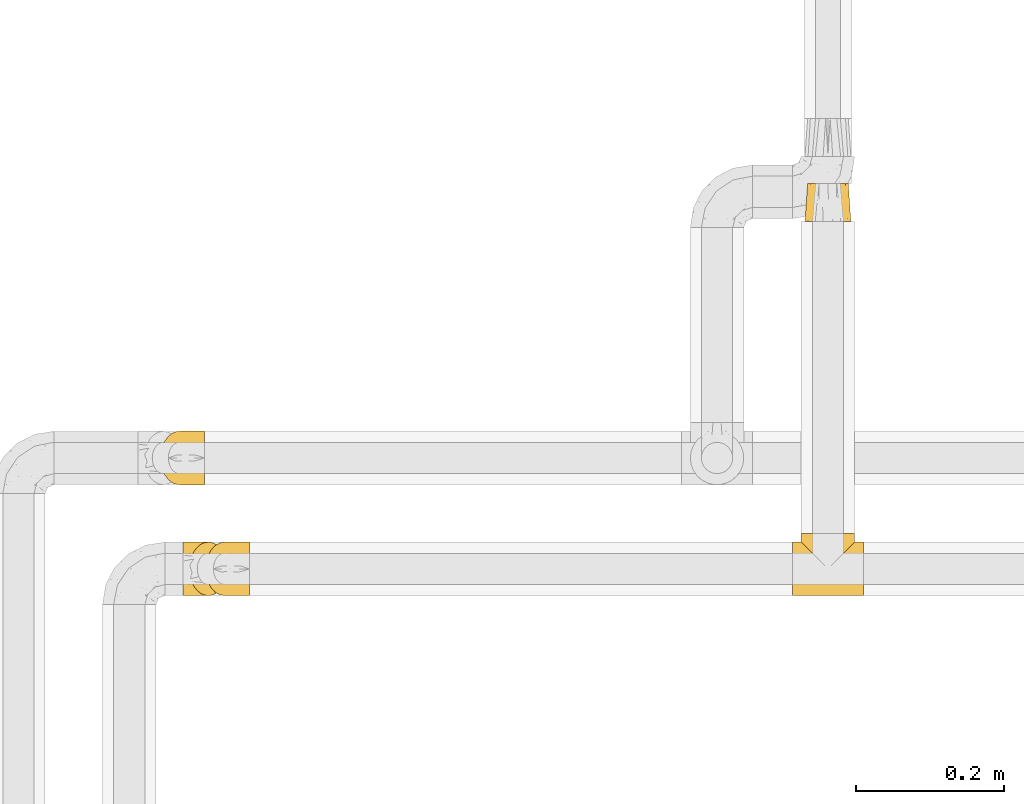
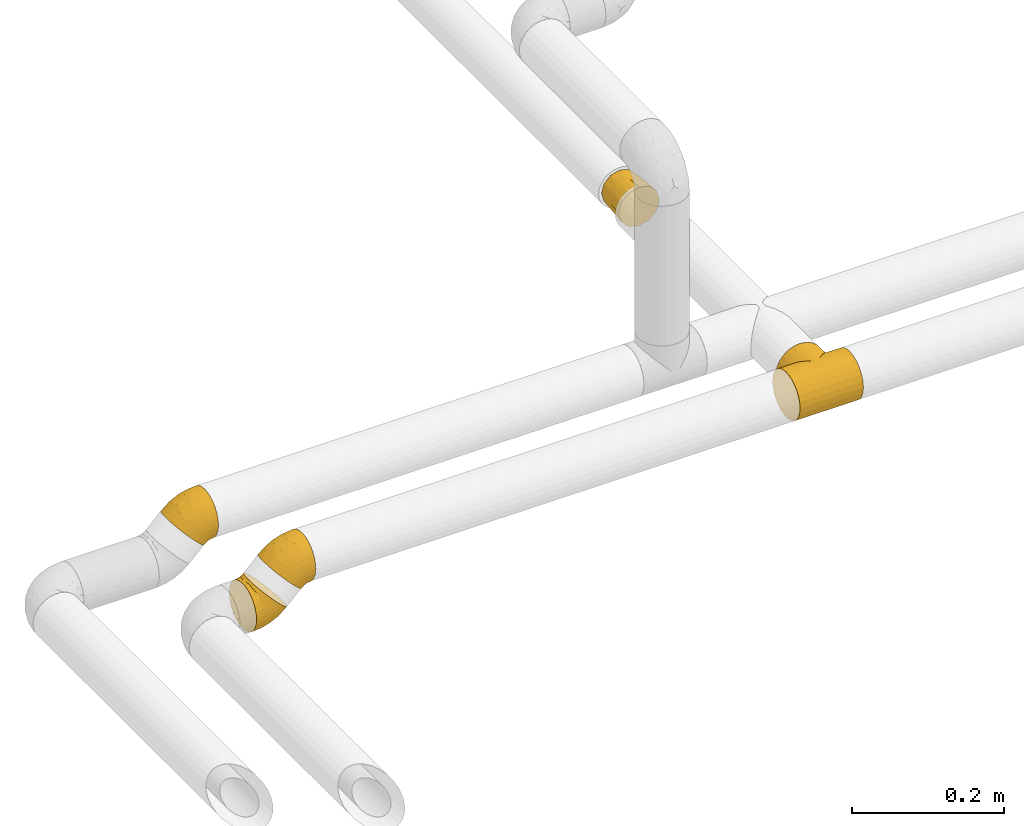
# One storey, part 19 of 39: 5 coverings.
"""IFC2X3 building model written with IfcOpenShell, lengths in millimetres."""

from ifc_helpers import new_model, entity, si_unit, converted_unit, derived_unit, direction, frame, origin, place, context, subcontext, project, spatial, faceted_brep, element, save


model = new_model("IFC2X3")

# Units and contexts
model_context = context("Model", 3, precision=0.01, world=origin(), true_north=direction((6.12303176911189e-17, 1.0)))
body_context = subcontext(model_context, "Body", "Model", "MODEL_VIEW")
ifc_project = project(units=[si_unit("LENGTHUNIT", "METRE", prefix="MILLI"), si_unit("AREAUNIT", "SQUARE_METRE"), si_unit("VOLUMEUNIT", "CUBIC_METRE"), converted_unit("PLANEANGLEUNIT", "DEGREE", entity("IfcRatioMeasure", 0.0174532925199433), si_unit("PLANEANGLEUNIT", "RADIAN"), dimensions=[0, 0, 0, 0, 0, 0, 0]), si_unit("MASSUNIT", "GRAM", prefix="KILO"), derived_unit("MASSDENSITYUNIT", [(si_unit("MASSUNIT", "GRAM", prefix="KILO"), 1), (si_unit("LENGTHUNIT", "METRE"), -3)]), derived_unit("MOMENTOFINERTIAUNIT", [(si_unit("LENGTHUNIT", "METRE"), 4)]), si_unit("TIMEUNIT", "SECOND"), si_unit("FREQUENCYUNIT", "HERTZ"), si_unit("THERMODYNAMICTEMPERATUREUNIT", "DEGREE_CELSIUS"), derived_unit("THERMALTRANSMITTANCEUNIT", [(si_unit("MASSUNIT", "GRAM", prefix="KILO"), 1), (si_unit("THERMODYNAMICTEMPERATUREUNIT", "KELVIN"), -1), (si_unit("TIMEUNIT", "SECOND"), -3)]), derived_unit("VOLUMETRICFLOWRATEUNIT", [(si_unit("LENGTHUNIT", "METRE"), 3), (si_unit("TIMEUNIT", "SECOND"), -1)]), derived_unit("MASSFLOWRATEUNIT", [(si_unit("MASSUNIT", "GRAM", prefix="KILO"), 1), (si_unit("TIMEUNIT", "SECOND"), -1)]), derived_unit("ROTATIONALFREQUENCYUNIT", [(si_unit("TIMEUNIT", "SECOND"), -1)]), si_unit("ELECTRICCURRENTUNIT", "AMPERE"), si_unit("ELECTRICVOLTAGEUNIT", "VOLT"), si_unit("POWERUNIT", "WATT"), si_unit("FORCEUNIT", "NEWTON", prefix="KILO"), si_unit("ILLUMINANCEUNIT", "LUX"), si_unit("LUMINOUSFLUXUNIT", "LUMEN"), si_unit("LUMINOUSINTENSITYUNIT", "CANDELA"), derived_unit("USERDEFINED", [(si_unit("MASSUNIT", "GRAM", prefix="KILO"), -1), (si_unit("LENGTHUNIT", "METRE"), -2), (si_unit("TIMEUNIT", "SECOND"), 3), (si_unit("LUMINOUSFLUXUNIT", "LUMEN"), 1)]), derived_unit("LINEARVELOCITYUNIT", [(si_unit("LENGTHUNIT", "METRE"), 1), (si_unit("TIMEUNIT", "SECOND"), -1)]), si_unit("PRESSUREUNIT", "PASCAL"), derived_unit("USERDEFINED", [(si_unit("LENGTHUNIT", "METRE"), -2), (si_unit("MASSUNIT", "GRAM", prefix="KILO"), 1), (si_unit("TIMEUNIT", "SECOND"), -2)]), derived_unit("LINEARFORCEUNIT", [(si_unit("MASSUNIT", "GRAM", prefix="KILO"), 1), (si_unit("LENGTHUNIT", "METRE"), 1), (si_unit("TIMEUNIT", "SECOND"), -2), (si_unit("LENGTHUNIT", "METRE"), -1)]), derived_unit("PLANARFORCEUNIT", [(si_unit("MASSUNIT", "GRAM", prefix="KILO"), 1), (si_unit("LENGTHUNIT", "METRE"), 1), (si_unit("TIMEUNIT", "SECOND"), -2), (si_unit("LENGTHUNIT", "METRE"), -2)])], contexts=[model_context])

# Site, building, storey
site_placement = place(None, origin())
site = spatial("IfcSite", under=ifc_project, at=site_placement, CompositionType="ELEMENT")
building_placement = place(site_placement, origin())
building = spatial("IfcBuilding", under=site, at=building_placement, CompositionType="ELEMENT")
storey_placement = place(building_placement, frame((0.0, 0.0, 24000.0)))
storey = spatial("IfcBuildingStorey", under=building, at=storey_placement, Name="07", CompositionType="ELEMENT", Elevation=24000.0)

# Coverings
covering_1_placement = place(storey_placement, frame((68741.41, 2687.56, 2992.16)))
element("IfcCovering", 1, at=covering_1_placement, inside=storey, Name=":ADSK_", ObjectType=":ADSK_", PredefinedType="INSULATION", context=body_context, shape_type="Brep", body=[
    faceted_brep([(10.58, 29.74, 76.81), (12.48, 22.08, 74.91), (15.53, 15.22, 71.86), (19.58, 9.49, 67.81), (24.43, 5.18, 62.96), (29.84, 2.5, 57.55), (35.54, 1.6, 51.85), (41.24, 2.5, 46.16), (46.65, 5.18, 40.74), (51.5, 9.5, 35.89), (55.55, 15.23, 31.84), (58.6, 22.09, 28.79), (60.49, 29.74, 26.9), (61.13, 37.8, 26.26), (60.49, 45.85, 26.9), (58.6, 53.51, 28.79), (55.55, 60.37, 31.84), (51.49, 66.1, 35.9), (46.64, 70.41, 40.75), (41.23, 73.09, 46.16), (35.54, 74.0, 51.85), (29.84, 73.09, 57.55), (24.43, 70.41, 62.96), (19.57, 66.09, 67.82), (15.52, 60.36, 71.87), (12.47, 53.5, 74.92), (10.58, 45.85, 76.81), (9.94, 37.8, 77.45), (1.6, 47.16, 72.76), (1.6, 55.9, 69.15), (1.6, 63.39, 63.39), (1.6, 69.15, 55.9), (1.6, 72.76, 47.16), (1.6, 74.0, 37.8), (1.6, 72.76, 28.43), (1.6, 69.15, 19.7), (1.6, 63.39, 12.2), (1.6, 55.9, 6.45), (1.6, 47.16, 2.83), (1.6, 37.8, 1.6), (1.6, 28.43, 2.83), (1.6, 19.7, 6.45), (1.6, 12.2, 12.2), (1.6, 6.45, 19.7), (1.6, 2.83, 28.43), (1.6, 1.6, 37.8), (1.6, 2.83, 47.16), (1.6, 6.45, 55.9), (1.6, 12.2, 63.39), (1.6, 19.7, 69.15), (1.6, 28.43, 72.76), (1.6, 37.8, 74.0), (40.9, 12.92, 22.74), (23.39, 37.8, 4.46), (14.99, 29.25, 3.7), (16.52, 16.37, 10.07), (43.7, 37.8, 12.88), (27.85, 28.37, 7.11), (16.2, 10.58, 15.43), (45.46, 26.39, 16.1), (32.41, 19.73, 12.65), (28.47, 8.23, 22.37), (28.27, 13.79, 15.59), (16.35, 4.79, 24.68), (16.28, 2.34, 32.48), (31.57, 4.14, 32.28), (16.21, 23.1, 6.04), (19.96, 1.6, 41.45), (29.27, 2.14, 39.15), (46.54, 19.09, 20.84), (40.55, 7.62, 30.06), (30.91, 1.6, 48.76), (26.28, 1.6, 45.67), (12.51, 1.6, 39.97), (7.05, 1.6, 38.88), (7.17, 30.94, 74.66), (7.72, 24.2, 72.71), (16.09, 3.85, 53.48), (16.64, 2.21, 47.28), (21.27, 2.29, 49.91), (12.03, 8.54, 61.24), (11.95, 3.41, 50.6), (6.97, 7.2, 57.65), (6.75, 11.87, 63.65), (6.73, 3.16, 48.68), (25.51, 2.54, 53.98), (5.81, 19.63, 69.65), (9.9, 16.09, 68.68), (19.14, 4.98, 58.19), (15.24, 10.44, 65.7), (6.11, 37.8, 74.89), (5.8, 55.94, 69.66), (6.75, 63.73, 63.65), (12.51, 74.0, 39.97), (11.94, 72.18, 50.61), (16.64, 73.38, 47.29), (7.72, 51.38, 72.71), (30.91, 74.0, 48.76), (9.89, 59.48, 68.68), (6.73, 72.43, 48.68), (7.05, 74.0, 38.88), (6.97, 68.39, 57.65), (19.13, 70.6, 58.2), (16.08, 71.73, 53.49), (12.02, 67.04, 61.25), (25.5, 73.05, 53.98), (21.26, 73.3, 49.91), (5.43, 44.89, 73.9), (26.28, 74.0, 45.67), (15.24, 65.14, 65.71), (19.96, 74.0, 41.45), (16.26, 73.25, 32.48), (31.56, 71.45, 32.29), (16.36, 70.8, 24.69), (40.9, 62.68, 22.75), (46.54, 56.51, 20.84), (32.4, 55.87, 12.65), (45.46, 49.21, 16.1), (14.99, 46.35, 3.71), (29.27, 73.45, 39.15), (27.84, 47.23, 7.11), (16.21, 65.01, 15.43), (16.52, 59.22, 10.07), (16.2, 52.49, 6.04), (28.47, 67.37, 22.38), (40.54, 67.98, 30.07), (28.28, 61.79, 15.59)], [[[0, 1, 2, 3, 4, 5, 6, 7, 8, 9, 10, 11, 12, 13, 14, 15, 16, 17, 18, 19, 20, 21, 22, 23, 24, 25, 26, 27]], [[28, 29, 30, 31, 32, 33, 34, 35, 36, 37, 38, 39, 40, 41, 42, 43, 44, 45, 46, 47, 48, 49, 50, 51]], [[9, 52, 10]], [[39, 53, 54]], [[41, 55, 42]], [[53, 56, 57]], [[58, 43, 42]], [[59, 60, 57]], [[61, 58, 62]], [[58, 63, 43]], [[64, 45, 44]], [[63, 61, 65]], [[54, 66, 40]], [[67, 64, 68]], [[55, 58, 42]], [[69, 52, 60]], [[59, 57, 56]], [[56, 12, 59]], [[11, 10, 69]], [[11, 69, 59]], [[65, 64, 63]], [[13, 12, 56]], [[70, 52, 9]], [[43, 63, 44]], [[60, 55, 66]], [[68, 6, 71, 72, 67]], [[8, 7, 65]], [[65, 61, 70]], [[59, 69, 60]], [[52, 69, 10]], [[8, 70, 9]], [[54, 57, 66]], [[7, 68, 65]], [[11, 59, 12]], [[64, 67, 73, 74, 45]], [[63, 64, 44]], [[66, 55, 41]], [[60, 52, 62]], [[65, 68, 64]], [[6, 68, 7]], [[62, 58, 55]], [[58, 61, 63]], [[60, 62, 55]], [[61, 62, 52]], [[40, 66, 41]], [[60, 66, 57]], [[65, 70, 8]], [[52, 70, 61]], [[39, 54, 40]], [[53, 57, 54]], [[75, 76, 0]], [[77, 78, 79]], [[80, 81, 77]], [[82, 83, 48]], [[84, 73, 81]], [[1, 0, 76]], [[85, 5, 4]], [[76, 75, 50]], [[86, 50, 49]], [[51, 50, 75]], [[86, 87, 76]], [[47, 84, 82]], [[78, 73, 67]], [[4, 88, 85]], [[89, 88, 3]], [[4, 3, 88]], [[85, 72, 71]], [[6, 5, 71]], [[46, 84, 47]], [[47, 82, 48]], [[73, 84, 74]], [[90, 75, 27]], [[72, 85, 79]], [[89, 87, 80]], [[1, 87, 2]], [[85, 71, 5]], [[1, 76, 87]], [[83, 49, 48]], [[77, 79, 88]], [[2, 89, 3]], [[67, 72, 79]], [[79, 85, 88]], [[87, 89, 2]], [[88, 89, 80]], [[81, 80, 82]], [[83, 82, 80]], [[80, 77, 88]], [[78, 77, 81]], [[80, 87, 83]], [[83, 87, 86]], [[73, 78, 81]], [[79, 78, 67]], [[46, 74, 84]], [[82, 84, 81]], [[46, 45, 74]], [[27, 75, 0]], [[75, 90, 51]], [[50, 86, 76]], [[83, 86, 49]], [[29, 91, 92]], [[93, 94, 95]], [[26, 25, 96]], [[21, 20, 97]], [[91, 28, 96]], [[25, 24, 98]], [[99, 100, 32]], [[101, 31, 30]], [[102, 103, 104]], [[94, 99, 101]], [[102, 105, 106]], [[91, 96, 98]], [[51, 90, 107]], [[103, 95, 94]], [[90, 27, 26]], [[92, 91, 98]], [[96, 25, 98]], [[97, 108, 105]], [[99, 32, 31]], [[98, 24, 109]], [[109, 24, 23]], [[102, 23, 22]], [[92, 104, 101]], [[21, 105, 22]], [[106, 103, 102]], [[105, 21, 97]], [[107, 96, 28]], [[109, 102, 104]], [[102, 22, 105]], [[96, 107, 26]], [[108, 110, 106]], [[106, 105, 108]], [[102, 109, 23]], [[98, 109, 104]], [[92, 101, 30]], [[104, 94, 101]], [[95, 106, 110]], [[104, 103, 94]], [[29, 92, 30]], [[98, 104, 92]], [[106, 95, 103]], [[93, 95, 110]], [[101, 99, 31]], [[93, 99, 94]], [[100, 99, 93]], [[100, 33, 32]], [[28, 91, 29]], [[51, 107, 28]], [[26, 107, 90]], [[111, 112, 113]], [[114, 115, 116]], [[111, 33, 100, 93, 110]], [[114, 17, 16]], [[117, 115, 15]], [[35, 34, 113]], [[38, 118, 39]], [[111, 110, 119]], [[117, 120, 116]], [[111, 113, 34]], [[121, 35, 113]], [[37, 122, 123]], [[33, 111, 34]], [[36, 122, 37]], [[18, 112, 19]], [[113, 124, 121]], [[112, 18, 125]], [[38, 123, 118]], [[125, 18, 17]], [[113, 112, 124]], [[112, 111, 119]], [[124, 125, 114]], [[120, 117, 56]], [[115, 16, 15]], [[14, 13, 56]], [[120, 56, 53]], [[14, 56, 117]], [[115, 117, 116]], [[115, 114, 16]], [[14, 117, 15]], [[126, 116, 122]], [[119, 20, 19]], [[123, 38, 37]], [[122, 121, 126]], [[121, 122, 36]], [[123, 116, 120]], [[119, 110, 108, 97, 20]], [[112, 119, 19]], [[35, 121, 36]], [[126, 124, 114]], [[124, 126, 121]], [[116, 126, 114]], [[116, 123, 122]], [[123, 120, 118]], [[114, 125, 17]], [[112, 125, 124]], [[120, 53, 118]], [[39, 118, 53]]]),
])
covering_2_placement = place(storey_placement, frame((68771.64, 2687.56, 3038.7)))
element("IfcCovering", 2, at=covering_2_placement, inside=storey, Name=":ADSK_", ObjectType=":ADSK_", PredefinedType="INSULATION", context=body_context, shape_type="Brep", body=[
    faceted_brep([(61.13, 45.85, 5.96), (61.13, 53.51, 8.64), (61.13, 60.37, 12.95), (61.13, 66.1, 18.69), (61.13, 70.41, 25.55), (61.13, 73.09, 33.2), (61.13, 74.0, 41.25), (61.13, 73.09, 49.31), (61.13, 70.41, 56.96), (61.13, 66.09, 63.83), (61.13, 60.36, 69.56), (61.13, 53.5, 73.87), (61.13, 45.85, 76.54), (61.13, 37.8, 77.45), (61.13, 29.74, 76.54), (61.13, 22.08, 73.86), (61.13, 15.22, 69.55), (61.13, 9.49, 63.82), (61.13, 5.18, 56.95), (61.13, 2.5, 49.3), (61.13, 1.6, 41.25), (61.13, 2.5, 33.19), (61.13, 5.18, 25.54), (61.13, 9.5, 18.68), (61.13, 15.23, 12.94), (61.13, 22.09, 8.63), (61.13, 29.74, 5.96), (61.13, 37.8, 5.05), (51.92, 28.43, 2.47), (49.36, 19.7, 5.02), (45.29, 12.2, 9.09), (39.99, 6.45, 14.39), (33.82, 2.83, 20.57), (27.19, 1.6, 27.19), (20.57, 2.83, 33.82), (14.39, 6.45, 39.99), (9.09, 12.2, 45.29), (5.02, 19.7, 49.36), (2.47, 28.43, 51.92), (1.6, 37.8, 52.79), (2.47, 47.16, 51.92), (5.02, 55.9, 49.36), (9.09, 63.39, 45.29), (14.39, 69.15, 39.99), (20.57, 72.76, 33.82), (27.19, 74.0, 27.19), (33.82, 72.76, 20.57), (39.99, 69.15, 14.39), (45.29, 63.39, 9.09), (49.36, 55.9, 5.02), (51.92, 47.16, 2.47), (52.79, 37.8, 1.6), (44.34, 62.67, 65.63), (19.03, 37.8, 66.17), (12.56, 46.34, 60.77), (18.15, 59.22, 57.35), (39.34, 37.8, 74.58), (24.06, 47.22, 67.46), (21.7, 65.01, 53.34), (42.87, 49.2, 73.56), (31.19, 55.86, 66.76), (35.29, 67.36, 57.1), (30.36, 61.8, 61.76), (28.36, 70.8, 46.9), (33.81, 73.25, 41.33), (44.49, 71.45, 52.29), (15.07, 52.49, 59.98), (42.76, 74.0, 37.6), (47.72, 73.45, 45.8), (46.98, 56.5, 70.97), (49.26, 67.97, 60.21), (55.68, 74.0, 40.17), (50.22, 74.0, 39.08), (36.45, 74.0, 33.38), (31.82, 74.0, 30.28), (57.2, 44.65, 5.07), (56.21, 51.39, 6.84), (48.53, 71.74, 26.36), (44.54, 73.38, 31.12), (49.68, 73.3, 32.54), (51.15, 67.05, 17.99), (43.56, 72.18, 25.46), (45.04, 68.39, 16.95), (49.12, 63.72, 12.56), (38.52, 72.43, 23.12), (55.54, 73.05, 32.66), (52.69, 55.96, 7.64), (54.9, 59.5, 11.23), (54.02, 70.61, 25.18), (56.57, 65.15, 17.11), (56.62, 37.8, 4.15), (52.7, 19.65, 7.64), (49.12, 11.87, 12.56), (36.45, 1.6, 33.38), (43.57, 3.41, 25.45), (44.54, 2.21, 31.11), (56.21, 24.21, 6.83), (55.68, 1.6, 40.17), (54.9, 16.11, 11.22), (38.52, 3.16, 23.12), (31.82, 1.6, 30.28), (45.03, 7.2, 16.95), (54.03, 4.99, 25.16), (48.53, 3.86, 26.34), (51.15, 8.55, 17.98), (55.54, 2.54, 32.65), (49.66, 2.29, 32.53), (55.43, 30.7, 4.38), (50.22, 1.6, 39.08), (56.58, 10.45, 17.1), (42.76, 1.6, 37.6), (33.81, 2.34, 41.32), (44.49, 4.14, 52.28), (28.37, 4.79, 46.9), (44.35, 12.91, 65.62), (46.98, 19.08, 70.96), (31.2, 19.72, 66.75), (42.87, 26.38, 73.55), (12.56, 29.24, 60.77), (47.71, 2.14, 45.8), (24.05, 28.36, 67.45), (21.71, 10.58, 53.34), (18.14, 16.37, 57.35), (15.06, 23.1, 59.97), (35.3, 8.22, 57.09), (49.26, 7.61, 60.2), (30.36, 13.8, 61.76)], [[[0, 1, 2, 3, 4, 5, 6, 7, 8, 9, 10, 11, 12, 13, 14, 15, 16, 17, 18, 19, 20, 21, 22, 23, 24, 25, 26, 27]], [[28, 29, 30, 31, 32, 33, 34, 35, 36, 37, 38, 39, 40, 41, 42, 43, 44, 45, 46, 47, 48, 49, 50, 51]], [[9, 52, 10]], [[39, 53, 54]], [[41, 55, 42]], [[53, 56, 57]], [[58, 43, 42]], [[59, 60, 57]], [[61, 58, 62]], [[58, 63, 43]], [[64, 45, 44]], [[63, 61, 65]], [[54, 66, 40]], [[67, 64, 68]], [[55, 58, 42]], [[69, 52, 60]], [[59, 57, 56]], [[56, 12, 59]], [[11, 10, 69]], [[11, 69, 59]], [[65, 64, 63]], [[13, 12, 56]], [[70, 52, 9]], [[43, 63, 44]], [[60, 55, 66]], [[68, 6, 71, 72, 67]], [[8, 7, 65]], [[65, 61, 70]], [[59, 69, 60]], [[52, 69, 10]], [[8, 70, 9]], [[54, 57, 66]], [[7, 68, 65]], [[11, 59, 12]], [[64, 67, 73, 74, 45]], [[63, 64, 44]], [[66, 55, 41]], [[60, 52, 62]], [[65, 68, 64]], [[6, 68, 7]], [[62, 58, 55]], [[58, 61, 63]], [[60, 62, 55]], [[61, 62, 52]], [[40, 66, 41]], [[60, 66, 57]], [[65, 70, 8]], [[52, 70, 61]], [[39, 54, 40]], [[53, 57, 54]], [[75, 76, 0]], [[77, 78, 79]], [[80, 81, 77]], [[82, 83, 48]], [[84, 73, 81]], [[1, 0, 76]], [[85, 5, 4]], [[76, 75, 50]], [[86, 50, 49]], [[51, 50, 75]], [[86, 87, 76]], [[47, 84, 82]], [[78, 73, 67]], [[4, 88, 85]], [[89, 88, 3]], [[4, 3, 88]], [[85, 72, 71]], [[6, 5, 71]], [[46, 84, 47]], [[47, 82, 48]], [[73, 84, 74]], [[90, 75, 27]], [[72, 85, 79]], [[89, 87, 80]], [[1, 87, 2]], [[85, 71, 5]], [[1, 76, 87]], [[83, 49, 48]], [[77, 79, 88]], [[2, 89, 3]], [[67, 72, 79]], [[79, 85, 88]], [[87, 89, 2]], [[88, 89, 80]], [[81, 80, 82]], [[83, 82, 80]], [[80, 77, 88]], [[78, 77, 81]], [[80, 87, 83]], [[83, 87, 86]], [[73, 78, 81]], [[79, 78, 67]], [[46, 74, 84]], [[82, 84, 81]], [[46, 45, 74]], [[27, 75, 0]], [[75, 90, 51]], [[50, 86, 76]], [[83, 86, 49]], [[29, 91, 92]], [[93, 94, 95]], [[26, 25, 96]], [[21, 20, 97]], [[91, 28, 96]], [[25, 24, 98]], [[99, 100, 32]], [[101, 31, 30]], [[102, 103, 104]], [[94, 99, 101]], [[102, 105, 106]], [[91, 96, 98]], [[51, 90, 107]], [[103, 95, 94]], [[90, 27, 26]], [[92, 91, 98]], [[96, 25, 98]], [[97, 108, 105]], [[99, 32, 31]], [[98, 24, 109]], [[109, 24, 23]], [[102, 23, 22]], [[92, 104, 101]], [[21, 105, 22]], [[106, 103, 102]], [[105, 21, 97]], [[107, 96, 28]], [[109, 102, 104]], [[102, 22, 105]], [[96, 107, 26]], [[108, 110, 106]], [[106, 105, 108]], [[102, 109, 23]], [[98, 109, 104]], [[92, 101, 30]], [[104, 94, 101]], [[95, 106, 110]], [[104, 103, 94]], [[29, 92, 30]], [[98, 104, 92]], [[106, 95, 103]], [[93, 95, 110]], [[101, 99, 31]], [[93, 99, 94]], [[100, 99, 93]], [[100, 33, 32]], [[28, 91, 29]], [[51, 107, 28]], [[26, 107, 90]], [[111, 112, 113]], [[114, 115, 116]], [[111, 33, 100, 93, 110]], [[114, 17, 16]], [[117, 115, 15]], [[35, 34, 113]], [[38, 118, 39]], [[111, 110, 119]], [[117, 120, 116]], [[111, 113, 34]], [[121, 35, 113]], [[37, 122, 123]], [[33, 111, 34]], [[36, 122, 37]], [[18, 112, 19]], [[113, 124, 121]], [[112, 18, 125]], [[38, 123, 118]], [[125, 18, 17]], [[113, 112, 124]], [[112, 111, 119]], [[124, 125, 114]], [[120, 117, 56]], [[115, 16, 15]], [[14, 13, 56]], [[120, 56, 53]], [[14, 56, 117]], [[115, 117, 116]], [[115, 114, 16]], [[14, 117, 15]], [[126, 116, 122]], [[119, 20, 19]], [[123, 38, 37]], [[122, 121, 126]], [[121, 122, 36]], [[123, 116, 120]], [[119, 110, 108, 97, 20]], [[112, 119, 19]], [[35, 121, 36]], [[126, 124, 114]], [[124, 126, 121]], [[116, 126, 114]], [[116, 123, 122]], [[123, 120, 118]], [[114, 125, 17]], [[112, 125, 124]], [[120, 53, 118]], [[39, 118, 53]]]),
])
covering_3_placement = place(storey_placement, frame((69567.01, 2687.56, 3042.17)))
element("IfcCovering", 3, at=covering_3_placement, inside=storey, Name=":ADSK_", ObjectType=":ADSK_", PredefinedType="INSULATION", context=body_context, shape_type="Brep", body=[
    faceted_brep([(41.92, 43.88, 2.11), (0.0, 37.8, 1.6), (0.0, 47.16, 2.83), (0.0, 55.9, 6.45), (35.92, 49.87, 3.67), (24.64, 61.15, 10.14), (0.0, 63.39, 12.2), (30.12, 55.68, 6.32), (48.0, 37.8, 1.6), (54.08, 43.88, 2.11), (96.0, 37.8, 1.6), (19.71, 66.09, 15.21), (0.0, 69.15, 19.7), (15.62, 70.18, 21.61), (0.0, 72.76, 28.43), (12.82, 72.98, 29.28), (0.0, 74.0, 37.8), (11.8, 74.0, 37.8), (12.81, 72.98, 46.3), (0.0, 72.76, 47.16), (15.61, 70.18, 53.97), (0.0, 69.15, 55.9), (19.7, 66.09, 60.37), (0.0, 63.39, 63.39), (24.64, 61.16, 65.45), (30.11, 55.69, 69.27), (0.0, 55.9, 69.15), (35.92, 49.88, 71.92), (0.0, 47.16, 72.76), (41.91, 43.88, 73.48), (0.0, 37.8, 74.0), (48.0, 37.8, 74.0), (54.09, 43.88, 73.48), (96.0, 37.8, 74.0), (96.0, 19.7, 69.15), (96.0, 12.2, 63.39), (96.0, 6.45, 55.9), (96.0, 2.83, 47.17), (96.0, 1.6, 37.8), (96.0, 2.83, 28.43), (96.0, 6.45, 19.7), (96.0, 12.2, 12.2), (96.0, 19.7, 6.45), (96.0, 28.43, 2.83), (96.0, 47.16, 2.83), (96.0, 55.9, 6.45), (96.0, 63.39, 12.2), (96.0, 69.15, 19.7), (96.0, 72.76, 28.43), (96.0, 74.0, 37.8), (96.0, 72.76, 47.17), (96.0, 69.15, 55.9), (96.0, 63.39, 63.39), (96.0, 55.9, 69.15), (96.0, 47.16, 72.76), (96.0, 28.43, 72.76), (0.0, 12.2, 12.2), (0.0, 6.45, 19.7), (0.0, 2.83, 28.43), (0.0, 1.6, 37.8), (0.0, 2.83, 47.16), (0.0, 6.45, 55.9), (0.0, 12.2, 63.39), (0.0, 19.7, 69.15), (0.0, 28.43, 72.76), (0.0, 28.43, 2.83), (0.0, 19.7, 6.45), (60.08, 49.87, 3.67), (65.88, 55.68, 6.32), (71.36, 61.15, 10.14), (76.29, 66.09, 15.21), (80.38, 70.18, 21.61), (83.18, 72.98, 29.28), (84.2, 74.0, 37.8), (83.19, 72.98, 46.3), (80.39, 70.18, 53.97), (76.3, 66.09, 60.37), (71.36, 61.16, 65.45), (65.89, 55.69, 69.27), (60.08, 49.88, 71.92), (13.03, 85.8, 28.43), (11.8, 85.8, 37.8), (13.03, 85.8, 47.16), (16.65, 85.8, 55.9), (22.4, 85.8, 63.39), (29.9, 85.8, 69.15), (38.63, 85.8, 72.76), (48.0, 85.8, 74.0), (57.37, 85.8, 72.76), (66.1, 85.8, 69.15), (73.6, 85.8, 63.39), (79.35, 85.8, 55.9), (82.97, 85.8, 47.17), (84.2, 85.8, 37.8), (82.97, 85.8, 28.43), (79.35, 85.8, 19.7), (73.6, 85.8, 12.2), (66.1, 85.8, 6.45), (57.37, 85.8, 2.83), (48.0, 85.8, 1.6), (38.63, 85.8, 2.83), (29.9, 85.8, 6.45), (22.4, 85.8, 12.2), (16.65, 85.8, 19.7)], [[[0, 1, 2]], [[2, 3, 4]], [[5, 3, 6]], [[5, 7, 3]], [[0, 8, 1]], [[8, 9, 10]], [[7, 4, 3]], [[0, 2, 4]], [[11, 6, 12]], [[13, 12, 14]], [[15, 14, 16]], [[13, 11, 12]], [[17, 15, 16]], [[13, 14, 15]], [[6, 11, 5]], [[18, 16, 19]], [[20, 19, 21]], [[22, 21, 23]], [[18, 17, 16]], [[22, 20, 21]], [[18, 19, 20]], [[23, 24, 22]], [[25, 24, 26]], [[26, 24, 23]], [[27, 26, 28]], [[29, 28, 30]], [[27, 25, 26]], [[31, 29, 30]], [[32, 31, 33]], [[27, 28, 29]], [[34, 35, 36, 37, 38, 39, 40, 41, 42, 43, 10, 44, 45, 46, 47, 48, 49, 50, 51, 52, 53, 54, 33, 55]], [[56, 57, 58, 59, 60, 61, 62, 63, 64, 30, 28, 26, 23, 21, 19, 16, 14, 12, 6, 3, 2, 1, 65, 66]], [[57, 56, 41, 40]], [[38, 59, 58, 39]], [[58, 57, 40, 39]], [[42, 66, 65, 43]], [[1, 8, 10, 43, 65]], [[41, 56, 66, 42]], [[67, 68, 45]], [[9, 67, 44]], [[10, 9, 44]], [[45, 69, 46]], [[45, 44, 67]], [[69, 45, 68]], [[70, 71, 47]], [[72, 73, 49]], [[71, 72, 48]], [[46, 70, 47]], [[47, 71, 48]], [[72, 49, 48]], [[70, 46, 69]], [[73, 74, 49]], [[75, 76, 51]], [[74, 75, 50]], [[49, 74, 50]], [[51, 50, 75]], [[52, 51, 76]], [[76, 77, 52]], [[78, 79, 53]], [[79, 32, 54]], [[77, 53, 52]], [[77, 78, 53]], [[53, 79, 54]], [[32, 33, 54]], [[31, 30, 64, 55, 33]], [[55, 64, 63, 34]], [[63, 62, 35, 34]], [[35, 62, 61, 36]], [[36, 61, 60, 37]], [[37, 60, 59, 38]], [[80, 81, 82, 83, 84, 85, 86, 87, 88, 89, 90, 91, 92, 93, 94, 95, 96, 97, 98, 99, 100, 101, 102, 103]], [[15, 81, 80]], [[103, 102, 11]], [[13, 80, 103]], [[15, 17, 81]], [[11, 13, 103]], [[15, 80, 13]], [[102, 5, 11]], [[7, 5, 101]], [[101, 5, 102]], [[4, 101, 100]], [[0, 100, 99]], [[4, 7, 101]], [[8, 0, 99]], [[4, 100, 0]], [[9, 99, 98]], [[98, 97, 67]], [[69, 97, 96]], [[69, 68, 97]], [[9, 8, 99]], [[68, 67, 97]], [[9, 98, 67]], [[70, 96, 95]], [[71, 95, 94]], [[72, 94, 93]], [[71, 70, 95]], [[73, 72, 93]], [[71, 94, 72]], [[96, 70, 69]], [[74, 93, 92]], [[75, 92, 91]], [[76, 91, 90]], [[74, 73, 93]], [[76, 75, 91]], [[74, 92, 75]], [[90, 77, 76]], [[78, 77, 89]], [[89, 77, 90]], [[79, 89, 88]], [[32, 88, 87]], [[79, 78, 89]], [[31, 32, 87]], [[79, 88, 32]], [[29, 87, 86]], [[86, 85, 27]], [[24, 85, 84]], [[24, 25, 85]], [[29, 31, 87]], [[25, 27, 85]], [[29, 86, 27]], [[22, 84, 83]], [[20, 83, 82]], [[18, 82, 81]], [[20, 22, 83]], [[17, 18, 81]], [[20, 82, 18]], [[84, 22, 24]]]),
])
covering_4_placement = place(storey_placement, frame((69582.42, 3195.35, 3047.41)))
element("IfcCovering", 4, at=covering_4_placement, inside=storey, Name=":ADSK_", ObjectType=":ADSK_", PredefinedType="INSULATION", context=body_context, shape_type="Brep", body=[
    faceted_brep([(59.44, 0.0, 17.1), (61.52, 0.0, 24.85), (63.6, 0.0, 32.6), (62.14, 0.0, 38.04), (60.68, 0.0, 43.48), (59.44, 0.0, 48.1), (53.77, 0.0, 53.77), (48.1, 0.0, 59.44), (40.35, 0.0, 61.52), (32.6, 0.0, 63.6), (27.15, 0.0, 62.14), (21.71, 0.0, 60.68), (17.1, 0.0, 59.44), (11.42, 0.0, 53.77), (5.75, 0.0, 48.1), (3.67, 0.0, 40.35), (1.6, 0.0, 32.6), (3.05, 0.0, 27.15), (4.51, 0.0, 21.71), (5.75, 0.0, 17.1), (11.42, 0.0, 11.42), (17.1, 0.0, 5.75), (24.85, 0.0, 3.67), (32.6, 0.0, 1.6), (38.04, 0.0, 3.05), (43.48, 0.0, 4.51), (48.1, 0.0, 5.75), (53.77, 0.0, 11.42), (46.35, 51.0, 56.41), (51.38, 51.0, 51.37), (56.41, 51.0, 46.34), (58.25, 51.0, 39.47), (60.1, 51.0, 32.59), (58.25, 51.0, 25.72), (56.41, 51.0, 18.84), (51.38, 51.0, 13.81), (46.35, 51.0, 8.78), (39.47, 51.0, 6.93), (32.6, 51.0, 5.09), (25.72, 51.0, 6.93), (18.85, 51.0, 8.78), (13.81, 51.0, 13.81), (8.78, 51.0, 18.84), (6.94, 51.0, 25.72), (5.1, 51.0, 32.59), (6.94, 51.0, 39.47), (8.78, 51.0, 46.34), (13.81, 51.0, 51.37), (18.85, 51.0, 56.41), (25.72, 51.0, 58.25), (32.6, 51.0, 60.09), (39.47, 51.0, 58.25), (6.2, 25.5, 19.99), (4.19, 24.88, 25.45), (10.36, 25.5, 13.59), (3.25, 24.18, 32.59), (19.99, 25.5, 6.2), (14.79, 25.5, 9.39), (32.6, 24.18, 3.25), (25.33, 25.5, 4.26), (45.2, 25.5, 6.2), (39.74, 24.88, 4.19), (51.6, 25.5, 10.36), (58.99, 25.5, 19.99), (55.8, 25.5, 14.79), (61.94, 24.18, 32.59), (60.93, 25.5, 25.32), (58.99, 25.5, 45.2), (61.0, 24.88, 39.74), (54.83, 25.5, 51.6), (45.2, 25.5, 58.99), (50.4, 25.5, 55.8), (32.6, 24.18, 61.93), (39.87, 25.5, 60.93), (19.99, 25.5, 58.99), (25.45, 24.88, 61.0), (13.59, 25.5, 54.83), (6.2, 25.5, 45.19), (9.39, 25.5, 50.4), (4.26, 25.5, 39.86)], [[[0, 1, 2, 3, 4, 5, 6, 7, 8, 9, 10, 11, 12, 13, 14, 15, 16, 17, 18, 19, 20, 21, 22, 23, 24, 25, 26, 27]], [[28, 29, 30, 31, 32, 33, 34, 35, 36, 37, 38, 39, 40, 41, 42, 43, 44, 45, 46, 47, 48, 49, 50, 51]], [[52, 43, 42]], [[52, 19, 18]], [[44, 43, 53]], [[17, 53, 18]], [[41, 54, 42]], [[17, 16, 55]], [[56, 21, 57]], [[41, 57, 54]], [[57, 41, 40]], [[58, 23, 59, 38]], [[57, 21, 20]], [[54, 19, 52]], [[53, 43, 52]], [[55, 44, 53]], [[57, 20, 54]], [[56, 57, 40]], [[19, 54, 20]], [[42, 54, 52]], [[18, 53, 52]], [[39, 59, 56]], [[56, 40, 39]], [[59, 22, 56]], [[22, 21, 56]], [[22, 59, 23]], [[55, 53, 17]], [[38, 59, 39]], [[60, 37, 36]], [[60, 26, 25]], [[38, 37, 61]], [[24, 61, 25]], [[35, 62, 36]], [[24, 23, 58]], [[63, 0, 64]], [[35, 64, 62]], [[64, 35, 34]], [[65, 2, 66, 32]], [[64, 0, 27]], [[62, 26, 60]], [[61, 37, 60]], [[58, 38, 61]], [[64, 27, 62]], [[63, 64, 34]], [[26, 62, 27]], [[36, 62, 60]], [[25, 61, 60]], [[33, 66, 63]], [[63, 34, 33]], [[66, 1, 63]], [[1, 0, 63]], [[1, 66, 2]], [[58, 61, 24]], [[32, 66, 33]], [[67, 31, 30]], [[67, 5, 4]], [[32, 31, 68]], [[3, 68, 4]], [[29, 69, 30]], [[3, 2, 65]], [[70, 7, 71]], [[29, 71, 69]], [[71, 29, 28]], [[72, 9, 73, 50]], [[71, 7, 6]], [[69, 5, 67]], [[68, 31, 67]], [[65, 32, 68]], [[71, 6, 69]], [[70, 71, 28]], [[5, 69, 6]], [[30, 69, 67]], [[4, 68, 67]], [[51, 73, 70]], [[70, 28, 51]], [[73, 8, 70]], [[8, 7, 70]], [[8, 73, 9]], [[65, 68, 3]], [[50, 73, 51]], [[74, 49, 48]], [[74, 12, 11]], [[50, 49, 75]], [[10, 75, 11]], [[47, 76, 48]], [[10, 9, 72]], [[77, 14, 78]], [[47, 78, 76]], [[78, 47, 46]], [[55, 16, 79, 44]], [[78, 14, 13]], [[76, 12, 74]], [[75, 49, 74]], [[72, 50, 75]], [[78, 13, 76]], [[77, 78, 46]], [[12, 76, 13]], [[48, 76, 74]], [[11, 75, 74]], [[45, 79, 77]], [[77, 46, 45]], [[79, 15, 77]], [[15, 14, 77]], [[15, 79, 16]], [[72, 75, 10]], [[44, 79, 45]]]),
])
covering_5_placement = place(storey_placement, frame((68710.77, 2837.56, 3038.75)))
element("IfcCovering", 5, at=covering_5_placement, inside=storey, Name=":ADSK_", ObjectType=":ADSK_", PredefinedType="INSULATION", context=body_context, shape_type="Brep", body=[
    faceted_brep([(52.14, 29.74, 2.24), (50.25, 22.08, 4.13), (47.2, 15.22, 7.18), (43.14, 9.49, 11.24), (38.29, 5.18, 16.09), (32.88, 2.5, 21.5), (27.19, 1.6, 27.19), (21.49, 2.5, 32.89), (16.08, 5.18, 38.31), (11.23, 9.5, 43.16), (7.18, 15.23, 47.21), (4.13, 22.09, 50.26), (2.24, 29.74, 52.15), (1.6, 37.8, 52.8), (2.24, 45.85, 52.15), (4.13, 53.51, 50.26), (7.18, 60.37, 47.21), (11.24, 66.1, 43.15), (16.09, 70.41, 38.3), (21.5, 73.09, 32.89), (27.19, 74.0, 27.2), (32.89, 73.09, 21.5), (38.3, 70.41, 16.08), (43.15, 66.09, 11.23), (47.2, 60.36, 7.18), (50.25, 53.5, 4.13), (52.14, 45.85, 2.24), (52.78, 37.8, 1.6), (61.13, 47.17, 6.28), (61.13, 55.9, 9.9), (61.13, 63.39, 15.65), (61.13, 69.15, 23.15), (61.13, 72.76, 31.88), (61.13, 74.0, 41.25), (61.13, 72.76, 50.62), (61.13, 69.15, 59.35), (61.13, 63.39, 66.85), (61.13, 55.89, 72.6), (61.13, 47.16, 76.22), (61.13, 37.79, 77.45), (61.13, 28.43, 76.22), (61.13, 19.69, 72.6), (61.13, 12.2, 66.85), (61.13, 6.44, 59.35), (61.13, 2.83, 50.62), (61.13, 1.6, 41.25), (61.13, 2.83, 31.88), (61.13, 6.45, 23.15), (61.13, 12.2, 15.65), (61.13, 19.7, 9.9), (61.13, 28.43, 6.28), (61.13, 37.8, 5.05), (21.82, 12.92, 56.31), (39.34, 37.79, 74.58), (47.73, 29.25, 75.34), (46.2, 16.37, 68.97), (19.03, 37.79, 66.17), (34.88, 28.37, 71.94), (46.52, 10.58, 63.62), (17.26, 26.39, 62.95), (30.32, 19.73, 66.4), (34.25, 8.23, 56.67), (34.45, 13.79, 63.45), (46.37, 4.79, 54.36), (46.45, 2.34, 46.57), (31.16, 4.14, 46.77), (46.52, 23.1, 73.01), (42.76, 1.6, 37.6), (33.45, 2.14, 39.89), (16.19, 19.09, 58.21), (22.18, 7.62, 48.99), (31.82, 1.6, 30.29), (36.44, 1.6, 33.38), (50.21, 1.6, 39.08), (55.67, 1.6, 40.16), (55.56, 30.94, 4.39), (55.01, 24.2, 6.34), (46.63, 3.85, 25.57), (46.09, 2.21, 31.76), (41.45, 2.29, 29.13), (50.7, 8.54, 17.81), (50.78, 3.41, 28.45), (55.75, 7.2, 21.39), (55.97, 11.87, 15.39), (56.0, 3.16, 30.36), (37.22, 2.54, 25.07), (56.92, 19.64, 9.4), (52.83, 16.1, 10.37), (43.58, 4.99, 20.85), (47.48, 10.44, 13.35), (56.61, 37.8, 4.15), (56.92, 55.94, 9.39), (55.97, 63.73, 15.4), (50.21, 74.0, 39.08), (50.78, 72.18, 28.44), (46.09, 73.38, 31.76), (55.01, 51.38, 6.34), (31.82, 74.0, 30.29), (52.83, 59.48, 10.36), (56.0, 72.43, 30.36), (55.67, 74.0, 40.17), (55.75, 68.39, 21.39), (43.59, 70.6, 20.84), (46.64, 71.73, 25.55), (50.7, 67.04, 17.79), (37.23, 73.05, 25.07), (41.47, 73.3, 29.14), (57.3, 44.89, 5.15), (36.44, 74.0, 33.38), (47.49, 65.14, 13.34), (42.76, 74.0, 37.6), (46.46, 73.25, 46.56), (31.16, 71.45, 46.76), (46.37, 70.8, 54.35), (21.83, 62.68, 56.3), (16.19, 56.51, 58.21), (30.32, 55.87, 66.4), (17.27, 49.21, 62.95), (47.74, 46.35, 75.34), (33.46, 73.45, 39.9), (34.89, 47.23, 71.94), (46.52, 65.01, 63.62), (46.21, 59.22, 68.97), (46.52, 52.49, 73.01), (34.26, 67.37, 56.67), (22.19, 67.98, 48.98), (34.45, 61.79, 63.46)], [[[0, 1, 2, 3, 4, 5, 6, 7, 8, 9, 10, 11, 12, 13, 14, 15, 16, 17, 18, 19, 20, 21, 22, 23, 24, 25, 26, 27]], [[28, 29, 30, 31, 32, 33, 34, 35, 36, 37, 38, 39, 40, 41, 42, 43, 44, 45, 46, 47, 48, 49, 50, 51]], [[9, 52, 10]], [[39, 53, 54]], [[41, 55, 42]], [[53, 56, 57]], [[58, 43, 42]], [[59, 60, 57]], [[61, 58, 62]], [[58, 63, 43]], [[64, 45, 44]], [[63, 61, 65]], [[54, 66, 40]], [[67, 64, 68]], [[55, 58, 42]], [[69, 52, 60]], [[59, 57, 56]], [[56, 12, 59]], [[11, 10, 69]], [[11, 69, 59]], [[65, 64, 63]], [[13, 12, 56]], [[70, 52, 9]], [[43, 63, 44]], [[60, 55, 66]], [[68, 6, 71, 72, 67]], [[8, 7, 65]], [[65, 61, 70]], [[59, 69, 60]], [[52, 69, 10]], [[8, 70, 9]], [[54, 57, 66]], [[7, 68, 65]], [[11, 59, 12]], [[64, 67, 73, 74, 45]], [[63, 64, 44]], [[66, 55, 41]], [[60, 52, 62]], [[65, 68, 64]], [[6, 68, 7]], [[62, 58, 55]], [[58, 61, 63]], [[60, 62, 55]], [[61, 62, 52]], [[40, 66, 41]], [[60, 66, 57]], [[65, 70, 8]], [[52, 70, 61]], [[39, 54, 40]], [[53, 57, 54]], [[75, 76, 0]], [[77, 78, 79]], [[80, 81, 77]], [[82, 83, 48]], [[84, 73, 81]], [[1, 0, 76]], [[85, 5, 4]], [[76, 75, 50]], [[86, 50, 49]], [[51, 50, 75]], [[86, 87, 76]], [[47, 84, 82]], [[78, 73, 67]], [[4, 88, 85]], [[89, 88, 3]], [[4, 3, 88]], [[85, 72, 71]], [[6, 5, 71]], [[46, 84, 47]], [[47, 82, 48]], [[73, 84, 74]], [[90, 75, 27]], [[72, 85, 79]], [[89, 87, 80]], [[1, 87, 2]], [[85, 71, 5]], [[1, 76, 87]], [[83, 49, 48]], [[77, 79, 88]], [[2, 89, 3]], [[67, 72, 79]], [[79, 85, 88]], [[87, 89, 2]], [[88, 89, 80]], [[81, 80, 82]], [[83, 82, 80]], [[80, 77, 88]], [[78, 77, 81]], [[80, 87, 83]], [[83, 87, 86]], [[73, 78, 81]], [[79, 78, 67]], [[46, 74, 84]], [[82, 84, 81]], [[46, 45, 74]], [[27, 75, 0]], [[75, 90, 51]], [[50, 86, 76]], [[83, 86, 49]], [[29, 91, 92]], [[93, 94, 95]], [[26, 25, 96]], [[21, 20, 97]], [[91, 28, 96]], [[25, 24, 98]], [[99, 100, 32]], [[101, 31, 30]], [[102, 103, 104]], [[94, 99, 101]], [[102, 105, 106]], [[91, 96, 98]], [[51, 90, 107]], [[103, 95, 94]], [[90, 27, 26]], [[92, 91, 98]], [[96, 25, 98]], [[97, 108, 105]], [[99, 32, 31]], [[98, 24, 109]], [[109, 24, 23]], [[102, 23, 22]], [[92, 104, 101]], [[21, 105, 22]], [[106, 103, 102]], [[105, 21, 97]], [[107, 96, 28]], [[109, 102, 104]], [[102, 22, 105]], [[96, 107, 26]], [[108, 110, 106]], [[106, 105, 108]], [[102, 109, 23]], [[98, 109, 104]], [[92, 101, 30]], [[104, 94, 101]], [[95, 106, 110]], [[104, 103, 94]], [[29, 92, 30]], [[98, 104, 92]], [[106, 95, 103]], [[93, 95, 110]], [[101, 99, 31]], [[93, 99, 94]], [[100, 99, 93]], [[100, 33, 32]], [[28, 91, 29]], [[51, 107, 28]], [[26, 107, 90]], [[111, 112, 113]], [[114, 115, 116]], [[111, 33, 100, 93, 110]], [[114, 17, 16]], [[117, 115, 15]], [[35, 34, 113]], [[38, 118, 39]], [[111, 110, 119]], [[117, 120, 116]], [[111, 113, 34]], [[121, 35, 113]], [[37, 122, 123]], [[33, 111, 34]], [[36, 122, 37]], [[18, 112, 19]], [[113, 124, 121]], [[112, 18, 125]], [[38, 123, 118]], [[125, 18, 17]], [[113, 112, 124]], [[112, 111, 119]], [[124, 125, 114]], [[120, 117, 56]], [[115, 16, 15]], [[14, 13, 56]], [[120, 56, 53]], [[14, 56, 117]], [[115, 117, 116]], [[115, 114, 16]], [[14, 117, 15]], [[126, 116, 122]], [[119, 20, 19]], [[123, 38, 37]], [[122, 121, 126]], [[121, 122, 36]], [[123, 116, 120]], [[119, 110, 108, 97, 20]], [[112, 119, 19]], [[35, 121, 36]], [[126, 124, 114]], [[124, 126, 121]], [[116, 126, 114]], [[116, 123, 122]], [[123, 120, 118]], [[114, 125, 17]], [[112, 125, 124]], [[120, 53, 118]], [[39, 118, 53]]]),
])

save(model, "model.ifc")
